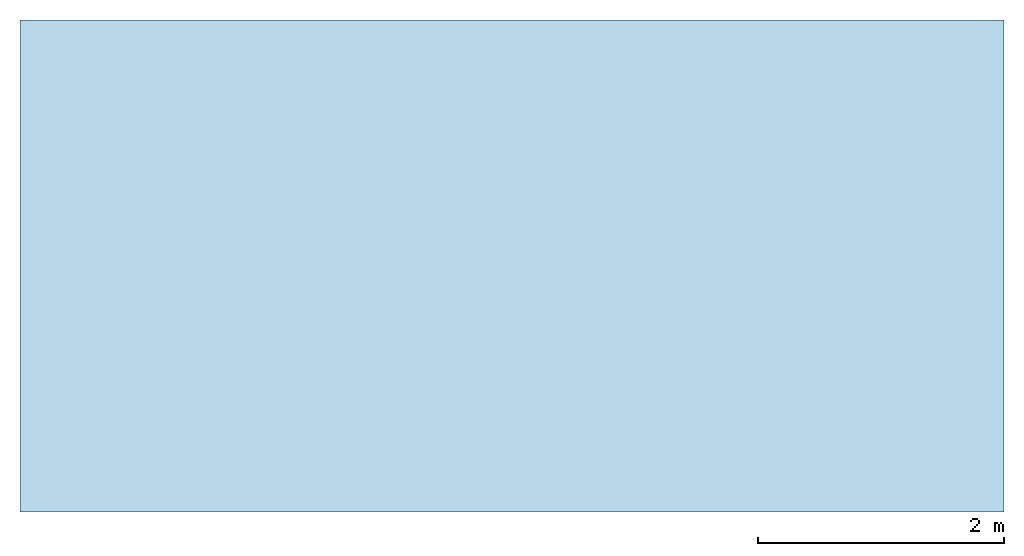
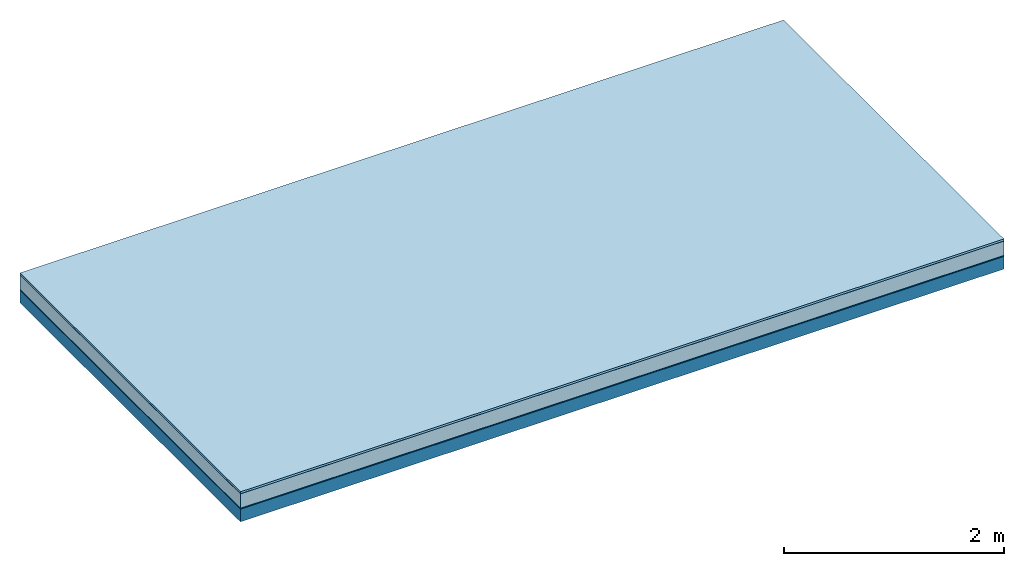
# One storey: 5 plates, 1 member, 1 element without a shape of its own.
"""IFC4 building model written with IfcOpenShell, lengths in metres."""

import ifcopenshell
import ifcopenshell.guid

model = None  # the IFC model being written
_history = None  # IfcOwnerHistory: only IFC2X3 demands one
_inside = {}  # id of a spatial element -> (the spatial element, [elements in it])
_under = {}  # id of a project, library or spatial element -> (it, [spatial elements below it])
_declared = {}  # id of a project -> (the project, [libraries it declares])
_typed = {}  # id of a type object -> (the type object, [elements of that type])
_made_of = {}  # id of a material, layer set ... -> (it, [elements and type objects made of it])


def new_model(schema):
    """Start an empty IFC model of exactly this schema.

    Asked for "IFC4X3", IfcOpenShell would pick the latest addendum, in which some entities
    have other attributes; the version numbers below select the first issue.
    IFC2X3 requires an IfcOwnerHistory on every rooted entity: one is made here for all.
    """
    global model, _history
    if schema == "IFC4X3":
        model = ifcopenshell.file(schema_version=(4, 3, 0, 0))
    else:
        model = ifcopenshell.file(schema=schema)
    _inside.clear()
    _under.clear()
    _declared.clear()
    _typed.clear()
    _made_of.clear()
    _history = None
    if model.schema == "IFC2X3":
        org = make("IfcOrganization", Name="unknown")
        user = make(
            "IfcPersonAndOrganization",
            ThePerson=make("IfcPerson", FamilyName="unknown"),
            TheOrganization=org,
        )
        app = make(
            "IfcApplication",
            ApplicationDeveloper=org,
            Version="unknown",
            ApplicationFullName="unknown",
            ApplicationIdentifier="unknown",
        )
        _history = make(
            "IfcOwnerHistory",
            OwningUser=user,
            OwningApplication=app,
            ChangeAction="ADDED",
            CreationDate=0,
        )
    return model


def make(cls, **values):
    """One entity of the class cls with the attributes given. An attribute that is None is left unset."""
    return model.create_entity(
        cls, **{name: value for name, value in values.items() if value is not None}
    )


def rooted(cls, **values):
    """An entity with a GlobalId (a new one), such as an element, a storey or a relation."""
    return make(cls, GlobalId=ifcopenshell.guid.new(), OwnerHistory=_history, **values)


def si_unit(unit_type, name, prefix=None):
    """IfcSIUnit, for example si_unit("LENGTHUNIT", "METRE", prefix="MILLI")."""
    return make("IfcSIUnit", UnitType=unit_type, Prefix=prefix, Name=name)


def derived_unit(unit_type, elements):
    """IfcDerivedUnit: a product of units, each with its exponent."""
    return make(
        "IfcDerivedUnit",
        Elements=[
            make("IfcDerivedUnitElement", Unit=unit, Exponent=power)
            for unit, power in elements
        ],
        UnitType=unit_type,
    )


def assignment(units):
    """IfcUnitAssignment: the units of a project."""
    return None if units is None else make("IfcUnitAssignment", Units=units)


def point(xyz):
    """IfcCartesianPoint."""
    return None if xyz is None else make("IfcCartesianPoint", Coordinates=xyz)


def direction(xyz):
    """IfcDirection."""
    return None if xyz is None else make("IfcDirection", DirectionRatios=xyz)


def frame(location, z_axis=None, x_axis=None):
    """IfcAxis2Placement3D, a coordinate frame: its origin and axes. An axis left out is left unset."""
    return make(
        "IfcAxis2Placement3D",
        Location=point(location),
        Axis=direction(z_axis),
        RefDirection=direction(x_axis),
    )


def frame_2d(location, x_axis=None):
    """IfcAxis2Placement2D, a coordinate frame in the plane: its origin and x axis."""
    return make(
        "IfcAxis2Placement2D", Location=point(location), RefDirection=direction(x_axis)
    )


def origin():
    """The frame at (0, 0, 0) with its axes left unset."""
    return frame((0.0, 0.0, 0.0))


def origin_with_axes():
    """The frame at (0, 0, 0) with the z axis (0, 0, 1) and the x axis (1, 0, 0) written out."""
    return frame((0.0, 0.0, 0.0), z_axis=(0.0, 0.0, 1.0), x_axis=(1.0, 0.0, 0.0))


def place(relative_to, where):
    """IfcLocalPlacement: puts the frame where relative to a parent placement (None: the world)."""
    return make(
        "IfcLocalPlacement", PlacementRelTo=relative_to, RelativePlacement=where
    )


def context(
    kind, dimensions, precision=None, world=None, true_north=None, identifier=None
):
    """IfcGeometricRepresentationContext, for example the 3D "Model" context."""
    return make(
        "IfcGeometricRepresentationContext",
        ContextIdentifier=identifier,
        ContextType=kind,
        CoordinateSpaceDimension=dimensions,
        Precision=precision,
        WorldCoordinateSystem=world,
        TrueNorth=true_north,
    )


def project(units=None, contexts=None):
    """IfcProject with its units and contexts."""
    return rooted(
        "IfcProject",
        Name="project",
        RepresentationContexts=contexts,
        UnitsInContext=assignment(units),
    )


def spatial(cls, under=None, at=None, **own):
    """A site, building, storey or space (cls), placed at a placement, below another one or the project."""
    s = rooted(cls, ObjectPlacement=at, **own)
    if under is not None:
        _under.setdefault(under.id(), (under, []))[1].append(s)
    return s


def profile(cls, at=None, kind="AREA", **sizes):
    """A parametric profile (cls). Its sizes go by their IFC names, for example OverallWidth=200.0."""
    return make(cls, ProfileType=kind, Position=at, **sizes)


def rectangle(**sizes):
    """IfcRectangleProfileDef."""
    return profile("IfcRectangleProfileDef", **sizes)


def extrude(swept, where, along, depth):
    """IfcExtrudedAreaSolid: the profile swept, set in the frame where, extruded along a direction by depth."""
    return make(
        "IfcExtrudedAreaSolid",
        SweptArea=swept,
        Position=where,
        ExtrudedDirection=direction(along),
        Depth=depth,
    )


def shape(context_of_items, identifier, shape_type, items):
    """IfcShapeRepresentation: the items that make up one representation, for example the "Body"."""
    return make(
        "IfcShapeRepresentation",
        ContextOfItems=context_of_items,
        RepresentationIdentifier=identifier,
        RepresentationType=shape_type,
        Items=items,
    )


def material(Name=None, Category=None):
    """IfcMaterial."""
    return make("IfcMaterial", Name=Name, Category=Category)


def layer(
    of_material, thickness, ventilated=None, Name=None, Category=None, Priority=None
):
    """IfcMaterialLayer: one layer of a wall or slab, of a material (None: an air gap)."""
    return make(
        "IfcMaterialLayer",
        Material=of_material,
        LayerThickness=thickness,
        IsVentilated=ventilated,
        Name=Name,
        Category=Category,
        Priority=Priority,
    )


def layer_set(layers, Name=None):
    """IfcMaterialLayerSet."""
    return make("IfcMaterialLayerSet", MaterialLayers=layers, LayerSetName=Name)


def made_of(thing, what):
    """Note that an element or type object is made of a material, layer set ...; save() writes the relation."""
    if what is not None:
        _made_of.setdefault(what.id(), (what, []))[1].append(thing)
    return thing


def type_object(cls, material=None, **own):
    """A type object (cls), such as IfcWallType, which elements share."""
    return made_of(rooted(cls, **own), material)


def element(
    cls,
    number,
    at=None,
    inside=None,
    cuts=None,
    type_object=None,
    material=None,
    context=None,
    identifier="Body",
    shape_type=None,
    held_by="IfcProductDefinitionShape",
    body=None,
    shapes=None,
    **own,
):
    """One element of the class cls, such as IfcWall. Its Tag is "e" and its number.

    at: its placement. inside: the storey or other place that contains it. cuts: it is an
    opening in that element (IfcRelVoidsElement). A single representation is given by context,
    identifier, shape_type and body (its items); several are given by shapes. held_by: the class
    of the entity that holds the representations. save() writes the other relations.
    """
    e = rooted(cls, Tag="e%d" % number, ObjectPlacement=at, **own)
    if body is not None:
        shapes = [shape(context, identifier, shape_type, body)]
    if shapes is not None:
        e.Representation = make(held_by, Representations=shapes)
    if inside is not None:
        _inside.setdefault(inside.id(), (inside, []))[1].append(e)
    if cuts is not None:
        rooted(
            "IfcRelVoidsElement", RelatingBuildingElement=cuts, RelatedOpeningElement=e
        )
    if type_object is not None:
        _typed.setdefault(type_object.id(), (type_object, []))[1].append(e)
    return made_of(e, material)


def aggregate(whole, parts):
    """IfcRelAggregates: a whole, such as a stair, and the parts it consists of."""
    return rooted("IfcRelAggregates", RelatingObject=whole, RelatedObjects=parts)


def save(model, path):
    """Write the relations noted so far, then the file.

    IfcRelAggregates (storeys below a building ...), IfcRelContainedInSpatialStructure (elements
    in a storey), IfcRelDefinesByType, IfcRelAssociatesMaterial and IfcRelDeclares: one each for
    every whole, place, type object, material and project.
    """
    for whole, parts in _under.values():
        aggregate(whole, parts)
    for where, things in _inside.values():
        rooted(
            "IfcRelContainedInSpatialStructure",
            RelatedElements=things,
            RelatingStructure=where,
        )
    for kind, things in _typed.values():
        rooted("IfcRelDefinesByType", RelatedObjects=things, RelatingType=kind)
    for what, things in _made_of.values():
        rooted("IfcRelAssociatesMaterial", RelatedObjects=things, RelatingMaterial=what)
    for by, libraries in _declared.values():
        rooted("IfcRelDeclares", RelatingContext=by, RelatedDefinitions=libraries)
    model.write(path)


model = new_model("IFC4")

# Units and contexts
plan_context = context("Plan", 3, precision=1e-05, world=origin(), true_north=direction((0.0, 1.0)))
model_context = context("Model", 3, precision=1e-05, world=origin(), true_north=direction((0.0, 1.0)))
ifc_project = project(units=[si_unit("LENGTHUNIT", "METRE"), derived_unit("SOUNDPRESSUREUNIT", [(si_unit("PRESSUREUNIT", "PASCAL", prefix="MICRO"), 0)]), si_unit("ENERGYUNIT", "JOULE", prefix="MEGA"), si_unit("MASSUNIT", "GRAM", prefix="KILO"), derived_unit("THERMALTRANSMITTANCEUNIT", [(si_unit("POWERUNIT", "WATT"), 1), (si_unit("AREAUNIT", "SQUARE_METRE"), -1), (si_unit("THERMODYNAMICTEMPERATUREUNIT", "KELVIN"), -1)]), derived_unit("AREADENSITYUNIT", [(si_unit("MASSUNIT", "GRAM", prefix="KILO"), 1), (si_unit("AREAUNIT", "SQUARE_METRE"), -1)]), derived_unit("USERDEFINED", [(si_unit("ENERGYUNIT", "JOULE", prefix="MEGA"), 1), (si_unit("AREAUNIT", "SQUARE_METRE"), -1)])], contexts=[plan_context, model_context])

# Site, building, storey
site = spatial("IfcSite", under=ifc_project)
building_placement = place(None, origin())
building = spatial("IfcBuilding", under=site, at=building_placement)
storey_placement = place(building_placement, origin())
storey = spatial("IfcBuildingStorey", under=building, at=storey_placement)

# Slab, member, plates
ifc_material_1 = material(Name="with tongue and groove", Category="07.009")
ifc_layer_1 = layer(ifc_material_1, 0.022, Name="Flooring")
ifc_material_2 = material(Category="09.006")
ifc_layer_2 = layer(ifc_material_2, 0.0005, Name="layer")
ifc_material_3 = material(Name="2x 60x80mm")
ifc_layer_3 = layer(ifc_material_3, 0.16, Name="On-material")
ifc_material_4 = material(Name="Wood fiber generic product", Category="10.009")
ifc_layer_4 = layer(ifc_material_4, 0.01, Name="Impact sound insulation")
ifc_material_5 = material(Name="protection", Category="09.007")
ifc_layer_5 = layer(ifc_material_5, 0.0005, Name="Sub-floor")
ifc_material_6 = material(Name="no composite action")
ifc_layer_6 = layer(ifc_material_6, 0.0, Name="Bond")
ifc_layer_7 = layer(None, 0.14, Name="Supporting structure")
ifc_layer_set = layer_set([ifc_layer_1, ifc_layer_2, ifc_layer_3, ifc_layer_4, ifc_layer_5, ifc_layer_6, ifc_layer_7])
slab_type = type_object("IfcSlabType", Name="A2025", PredefinedType="NOTDEFINED", material=ifc_layer_set)
slab_placement = place(None, frame((0.0, 0.0, 0.0), z_axis=(0.0, 0.0, -1.0), x_axis=(1.0, 0.0, 0.0)))
slab = element("IfcSlab", 1, at=slab_placement, inside=storey, type_object=slab_type, material=ifc_layer_set, Name="Slab #1")
ifc_material_7 = material(Name="Solid timber panel")
member_placement = place(slab_placement, origin())
member = element("IfcMember", 2, at=member_placement, material=ifc_material_7, Name="Supporting structure", context=plan_context, shape_type="SweptSolid", body=[
    extrude(rectangle(XDim=1.0, YDim=0.14, at=frame_2d((0.5, 0.07), x_axis=(1.0, 0.0))), frame((0.0, 4.0, 0.193), z_axis=(0.0, -1.0, 0.0), x_axis=(1.0, 0.0, 0.0)), (0.0, 0.0, 1.0), 4.0),
    extrude(rectangle(XDim=1.0, YDim=0.14, at=frame_2d((0.5, 0.07), x_axis=(1.0, 0.0))), frame((1.0, 4.0, 0.193), z_axis=(0.0, -1.0, 0.0), x_axis=(1.0, 0.0, 0.0)), (0.0, 0.0, 1.0), 4.0),
    extrude(rectangle(XDim=1.0, YDim=0.14, at=frame_2d((0.5, 0.07), x_axis=(1.0, 0.0))), frame((2.0, 4.0, 0.193), z_axis=(0.0, -1.0, 0.0), x_axis=(1.0, 0.0, 0.0)), (0.0, 0.0, 1.0), 4.0),
    extrude(rectangle(XDim=1.0, YDim=0.14, at=frame_2d((0.5, 0.07), x_axis=(1.0, 0.0))), frame((3.0, 4.0, 0.193), z_axis=(0.0, -1.0, 0.0), x_axis=(1.0, 0.0, 0.0)), (0.0, 0.0, 1.0), 4.0),
    extrude(rectangle(XDim=1.0, YDim=0.14, at=frame_2d((0.5, 0.07), x_axis=(1.0, 0.0))), frame((4.0, 4.0, 0.193), z_axis=(0.0, -1.0, 0.0), x_axis=(1.0, 0.0, 0.0)), (0.0, 0.0, 1.0), 4.0),
    extrude(rectangle(XDim=1.0, YDim=0.14, at=frame_2d((0.5, 0.07), x_axis=(1.0, 0.0))), frame((5.0, 4.0, 0.193), z_axis=(0.0, -1.0, 0.0), x_axis=(1.0, 0.0, 0.0)), (0.0, 0.0, 1.0), 4.0),
    extrude(rectangle(XDim=1.0, YDim=0.14, at=frame_2d((0.5, 0.07), x_axis=(1.0, 0.0))), frame((6.0, 4.0, 0.193), z_axis=(0.0, -1.0, 0.0), x_axis=(1.0, 0.0, 0.0)), (0.0, 0.0, 1.0), 4.0),
    extrude(rectangle(XDim=1.0, YDim=0.14, at=frame_2d((0.5, 0.07), x_axis=(1.0, 0.0))), frame((7.0, 4.0, 0.193), z_axis=(0.0, -1.0, 0.0), x_axis=(1.0, 0.0, 0.0)), (0.0, 0.0, 1.0), 4.0),
])
plate_1_placement = place(slab_placement, origin())
plate_1 = element("IfcPlate", 3, at=plate_1_placement, material=ifc_material_1, Name="Flooring", context=plan_context, shape_type="SweptSolid", body=[
    extrude(rectangle(XDim=8.0, YDim=4.0, at=frame_2d((4.0, 2.0), x_axis=(1.0, 0.0))), origin_with_axes(), (0.0, 0.0, 1.0), 0.022),
])
plate_2_placement = place(slab_placement, origin())
plate_2 = element("IfcPlate", 4, at=plate_2_placement, material=ifc_material_2, Name="layer", context=plan_context, shape_type="SweptSolid", body=[
    extrude(rectangle(XDim=8.0, YDim=4.0, at=frame_2d((4.0, 2.0), x_axis=(1.0, 0.0))), frame((0.0, 0.0, 0.022), z_axis=(0.0, 0.0, 1.0), x_axis=(1.0, 0.0, 0.0)), (0.0, 0.0, 1.0), 0.0005),
])
plate_3_placement = place(slab_placement, origin())
plate_3 = element("IfcPlate", 5, at=plate_3_placement, material=ifc_material_3, Name="On-material", context=plan_context, shape_type="SweptSolid", body=[
    extrude(rectangle(XDim=8.0, YDim=4.0, at=frame_2d((4.0, 2.0), x_axis=(1.0, 0.0))), frame((0.0, 0.0, 0.0225), z_axis=(0.0, 0.0, 1.0), x_axis=(1.0, 0.0, 0.0)), (0.0, 0.0, 1.0), 0.16),
])
plate_4_placement = place(slab_placement, origin())
plate_4 = element("IfcPlate", 6, at=plate_4_placement, material=ifc_material_4, Name="Impact sound insulation", context=plan_context, shape_type="SweptSolid", body=[
    extrude(rectangle(XDim=8.0, YDim=4.0, at=frame_2d((4.0, 2.0), x_axis=(1.0, 0.0))), frame((0.0, 0.0, 0.1825), z_axis=(0.0, 0.0, 1.0), x_axis=(1.0, 0.0, 0.0)), (0.0, 0.0, 1.0), 0.01),
])
plate_5_placement = place(slab_placement, origin())
plate_5 = element("IfcPlate", 7, at=plate_5_placement, material=ifc_material_5, Name="Sub-floor", context=plan_context, shape_type="SweptSolid", body=[
    extrude(rectangle(XDim=8.0, YDim=4.0, at=frame_2d((4.0, 2.0), x_axis=(1.0, 0.0))), frame((0.0, 0.0, 0.1925), z_axis=(0.0, 0.0, 1.0), x_axis=(1.0, 0.0, 0.0)), (0.0, 0.0, 1.0), 0.0005),
])
aggregate(slab, [plate_1, plate_2, plate_3, plate_4, plate_5, member])

save(model, "model.ifc")
